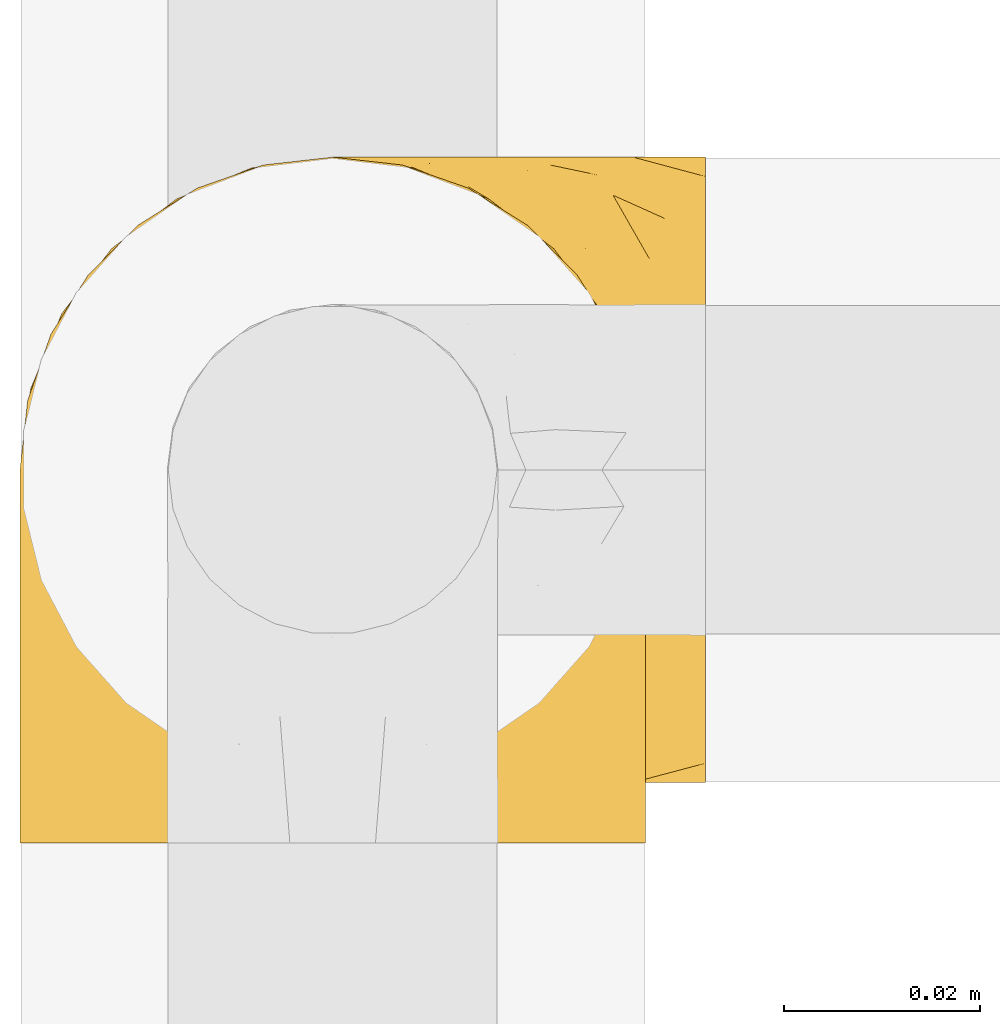
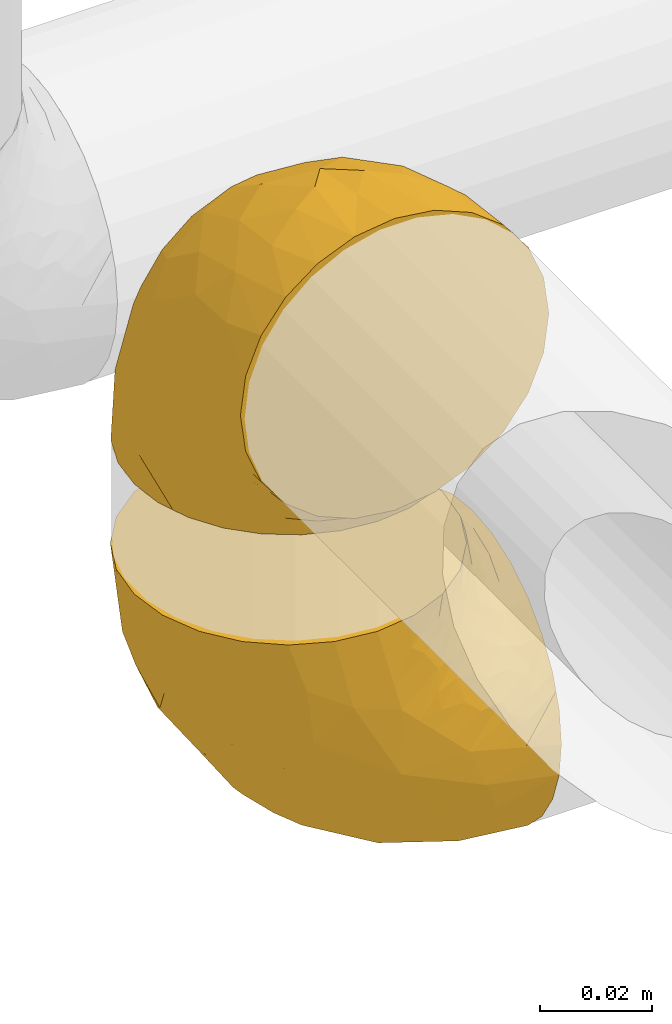
# One storey, part 10 of 39: 2 coverings.
"""IFC2X3 building model written with IfcOpenShell, lengths in millimetres."""

from ifc_helpers import new_model, entity, si_unit, converted_unit, derived_unit, direction, frame, origin, place, context, subcontext, project, spatial, faceted_brep, element, save


model = new_model("IFC2X3")

# Units and contexts
model_context = context("Model", 3, precision=0.01, world=origin(), true_north=direction((6.12303176911189e-17, 1.0)))
body_context = subcontext(model_context, "Body", "Model", "MODEL_VIEW")
ifc_project = project(units=[si_unit("LENGTHUNIT", "METRE", prefix="MILLI"), si_unit("AREAUNIT", "SQUARE_METRE"), si_unit("VOLUMEUNIT", "CUBIC_METRE"), converted_unit("PLANEANGLEUNIT", "DEGREE", entity("IfcRatioMeasure", 0.0174532925199433), si_unit("PLANEANGLEUNIT", "RADIAN"), dimensions=[0, 0, 0, 0, 0, 0, 0]), si_unit("MASSUNIT", "GRAM", prefix="KILO"), derived_unit("MASSDENSITYUNIT", [(si_unit("MASSUNIT", "GRAM", prefix="KILO"), 1), (si_unit("LENGTHUNIT", "METRE"), -3)]), derived_unit("MOMENTOFINERTIAUNIT", [(si_unit("LENGTHUNIT", "METRE"), 4)]), si_unit("TIMEUNIT", "SECOND"), si_unit("FREQUENCYUNIT", "HERTZ"), si_unit("THERMODYNAMICTEMPERATUREUNIT", "DEGREE_CELSIUS"), derived_unit("THERMALTRANSMITTANCEUNIT", [(si_unit("MASSUNIT", "GRAM", prefix="KILO"), 1), (si_unit("THERMODYNAMICTEMPERATUREUNIT", "KELVIN"), -1), (si_unit("TIMEUNIT", "SECOND"), -3)]), derived_unit("VOLUMETRICFLOWRATEUNIT", [(si_unit("LENGTHUNIT", "METRE"), 3), (si_unit("TIMEUNIT", "SECOND"), -1)]), derived_unit("MASSFLOWRATEUNIT", [(si_unit("MASSUNIT", "GRAM", prefix="KILO"), 1), (si_unit("TIMEUNIT", "SECOND"), -1)]), derived_unit("ROTATIONALFREQUENCYUNIT", [(si_unit("TIMEUNIT", "SECOND"), -1)]), si_unit("ELECTRICCURRENTUNIT", "AMPERE"), si_unit("ELECTRICVOLTAGEUNIT", "VOLT"), si_unit("POWERUNIT", "WATT"), si_unit("FORCEUNIT", "NEWTON", prefix="KILO"), si_unit("ILLUMINANCEUNIT", "LUX"), si_unit("LUMINOUSFLUXUNIT", "LUMEN"), si_unit("LUMINOUSINTENSITYUNIT", "CANDELA"), derived_unit("USERDEFINED", [(si_unit("MASSUNIT", "GRAM", prefix="KILO"), -1), (si_unit("LENGTHUNIT", "METRE"), -2), (si_unit("TIMEUNIT", "SECOND"), 3), (si_unit("LUMINOUSFLUXUNIT", "LUMEN"), 1)]), derived_unit("LINEARVELOCITYUNIT", [(si_unit("LENGTHUNIT", "METRE"), 1), (si_unit("TIMEUNIT", "SECOND"), -1)]), si_unit("PRESSUREUNIT", "PASCAL"), derived_unit("USERDEFINED", [(si_unit("LENGTHUNIT", "METRE"), -2), (si_unit("MASSUNIT", "GRAM", prefix="KILO"), 1), (si_unit("TIMEUNIT", "SECOND"), -2)]), derived_unit("LINEARFORCEUNIT", [(si_unit("MASSUNIT", "GRAM", prefix="KILO"), 1), (si_unit("LENGTHUNIT", "METRE"), 1), (si_unit("TIMEUNIT", "SECOND"), -2), (si_unit("LENGTHUNIT", "METRE"), -1)]), derived_unit("PLANARFORCEUNIT", [(si_unit("MASSUNIT", "GRAM", prefix="KILO"), 1), (si_unit("LENGTHUNIT", "METRE"), 1), (si_unit("TIMEUNIT", "SECOND"), -2), (si_unit("LENGTHUNIT", "METRE"), -2)])], contexts=[model_context])

# Site, building, storey
site_placement = place(None, origin())
site = spatial("IfcSite", under=ifc_project, at=site_placement, CompositionType="ELEMENT")
building_placement = place(site_placement, origin())
building = spatial("IfcBuilding", under=site, at=building_placement, CompositionType="ELEMENT")
storey_placement = place(building_placement, frame((0.0, 0.0, 24000.0)))
storey = spatial("IfcBuildingStorey", under=building, at=storey_placement, Name="07", CompositionType="ELEMENT", Elevation=24000.0)

# Coverings
covering_1_placement = place(storey_placement, frame((26666.66, 8211.58, 3260.4)))
element("IfcCovering", 1, at=covering_1_placement, inside=storey, Name=":ADSK_", ObjectType=":ADSK_", PredefinedType="INSULATION", context=body_context, shape_type="Brep", body=[
    faceted_brep([(26.36, 70.65, 1.6), (33.45, 71.45, 1.6), (40.54, 70.65, 1.6), (47.27, 68.29, 1.6), (53.31, 64.49, 1.6), (58.35, 59.45, 1.6), (62.14, 53.41, 1.6), (64.5, 46.68, 1.6), (65.3, 39.6, 1.6), (64.86, 35.69, 1.6), (64.5, 32.5, 1.6), (63.32, 29.14, 1.6), (62.14, 25.77, 1.6), (58.34, 19.73, 1.6), (53.3, 14.69, 1.6), (47.26, 10.9, 1.6), (40.53, 8.54, 1.6), (33.45, 7.75, 1.6), (26.35, 8.54, 1.6), (19.62, 10.9, 1.6), (13.58, 14.7, 1.6), (8.54, 19.74, 1.6), (4.75, 25.78, 1.6), (3.57, 29.15, 1.6), (2.39, 32.51, 1.6), (2.03, 35.69, 1.6), (1.81, 37.64, 1.6), (1.6, 39.6, 1.6), (2.39, 46.69, 1.6), (4.75, 53.42, 1.6), (8.55, 59.46, 1.6), (13.59, 64.5, 1.6), (19.63, 68.29, 1.6), (61.03, 1.6, 23.67), (62.62, 1.6, 27.51), (64.21, 1.6, 31.35), (64.78, 1.6, 35.67), (65.04, 1.6, 37.63), (65.3, 1.6, 39.6), (64.21, 1.6, 47.84), (61.03, 1.6, 55.52), (55.97, 1.6, 62.12), (49.37, 1.6, 67.18), (41.69, 1.6, 70.36), (33.45, 1.6, 71.45), (25.2, 1.6, 70.36), (17.52, 1.6, 67.18), (10.92, 1.6, 62.12), (5.86, 1.6, 55.52), (2.68, 1.6, 47.84), (1.6, 1.6, 39.6), (2.11, 1.6, 35.67), (2.68, 1.6, 31.35), (4.27, 1.6, 27.51), (5.86, 1.6, 23.67), (8.39, 1.6, 20.37), (10.92, 1.6, 17.07), (17.52, 1.6, 12.01), (25.2, 1.6, 8.83), (33.45, 1.6, 7.75), (41.69, 1.6, 8.83), (49.37, 1.6, 12.01), (55.97, 1.6, 17.07), (58.5, 1.6, 20.37), (2.87, 35.56, 33.94), (1.6, 34.5, 20.6), (1.6, 31.03, 24.07), (1.6, 27.55, 27.55), (1.6, 24.07, 31.03), (1.6, 20.6, 34.5), (33.45, 14.96, 68.79), (10.76, 32.2, 53.62), (5.89, 25.13, 50.17), (9.64, 17.37, 58.62), (22.45, 17.86, 67.51), (16.56, 27.91, 61.03), (15.17, 13.85, 64.5), (12.49, 61.37, 17.98), (25.02, 34.87, 61.71), (18.64, 44.22, 52.25), (2.29, 43.56, 16.72), (6.11, 40.93, 39.09), (5.18, 48.36, 25.86), (2.43, 17.22, 44.07), (11.11, 44.67, 44.36), (26.19, 63.86, 31.35), (24.02, 68.09, 17.72), (19.02, 61.87, 29.45), (4.77, 12.15, 52.37), (1.6, 17.69, 35.28), (1.6, 14.79, 36.06), (1.6, 11.89, 36.84), (1.6, 8.99, 37.61), (1.6, 7.14, 38.11), (1.6, 5.29, 38.61), (7.57, 56.77, 14.07), (17.54, 66.08, 13.65), (33.45, 68.79, 14.96), (4.36, 51.2, 13.32), (1.6, 39.1, 3.44), (1.6, 38.61, 5.29), (1.6, 37.61, 8.99), (1.6, 36.84, 11.89), (1.6, 36.06, 14.79), (1.6, 35.28, 17.69), (9.86, 54.2, 29.19), (14.05, 58.65, 28.91), (28.37, 21.36, 68.17), (33.45, 66.13, 28.33), (25.8, 46.99, 53.45), (33.45, 39.66, 58.56), (33.45, 50.99, 50.99), (22.54, 55.34, 43.14), (15.6, 53.83, 39.23), (33.45, 28.33, 66.13), (28.45, 55.34, 45.6), (33.45, 58.56, 39.66), (9.47, 6.06, 18.04), (5.83, 8.03, 22.76), (5.65, 11.06, 21.95), (2.31, 8.19, 32.18), (2.89, 10.89, 29.08), (2.68, 24.37, 20.77), (22.04, 9.23, 4.75), (5.47, 22.33, 11.03), (5.05, 24.59, 6.78), (7.86, 20.19, 5.68), (25.25, 5.45, 7.71), (28.09, 7.56, 4.42), (33.45, 5.94, 5.94), (12.77, 6.36, 14.52), (2.62, 29.84, 11.63), (3.56, 28.12, 6.6), (11.92, 14.94, 7.33), (11.98, 11.12, 12.48), (17.45, 9.87, 7.99), (17.1, 6.36, 11.14), (7.66, 16.34, 14.07), (4.47, 22.18, 15.37), (7.62, 18.62, 10.81), (2.29, 32.34, 7.89), (3.16, 15.29, 26.18), (16.64, 11.7, 5.8), (12.23, 13.14, 9.94), (4.54, 15.04, 22.23), (7.84, 10.61, 18.39), (2.55, 27.21, 17.71), (7.37, 14.05, 16.87), (3.18, 27.14, 13.24), (4.97, 5.74, 24.95), (2.38, 19.92, 26.59), (1.99, 23.61, 26.16), (3.56, 19.14, 22.11), (4.66, 20.12, 17.43), (44.85, 9.23, 4.75), (50.24, 11.69, 5.8), (49.43, 9.87, 7.99), (59.23, 16.33, 14.07), (54.76, 13.17, 10.06), (59.54, 18.65, 11.54), (41.64, 5.45, 7.71), (64.6, 32.33, 7.89), (65.3, 37.61, 8.99), (65.3, 36.84, 11.89), (65.3, 36.06, 14.79), (38.79, 7.56, 4.42), (62.38, 14.85, 22.42), (64.44, 17.26, 27.95), (61.27, 10.58, 22.22), (65.3, 3.44, 39.1), (65.3, 11.89, 36.84), (65.3, 8.99, 37.61), (65.3, 5.29, 38.61), (59.93, 5.65, 21.49), (62.73, 6.88, 26.52), (60.51, 14.93, 18.09), (59.05, 10.6, 18.39), (56.02, 11.09, 13.88), (49.79, 6.36, 11.14), (64.58, 8.19, 32.18), (65.3, 20.6, 34.5), (65.3, 24.07, 31.03), (64.27, 29.86, 11.65), (59.01, 20.16, 5.67), (61.84, 24.58, 6.81), (65.3, 38.61, 5.29), (65.3, 38.11, 7.14), (54.97, 14.93, 7.34), (65.3, 14.79, 36.06), (64.66, 12.32, 31.38), (63.94, 23.91, 19.83), (65.3, 27.55, 27.55), (63.6, 19.33, 22.94), (63.33, 28.11, 6.6), (57.32, 6.0, 17.93), (54.15, 6.44, 14.52), (64.5, 28.13, 17.45), (61.42, 22.32, 11.03), (65.3, 35.28, 17.69), (65.3, 34.5, 20.6), (63.43, 26.65, 12.33), (64.69, 15.34, 30.27), (65.3, 17.69, 35.28), (62.87, 10.31, 25.9), (65.3, 31.03, 24.07), (57.25, 17.37, 58.62), (62.54, 51.19, 13.32), (64.6, 43.56, 16.72), (64.46, 17.22, 44.07), (41.87, 34.87, 61.71), (44.44, 17.86, 67.51), (50.33, 27.92, 61.03), (61.0, 25.12, 50.18), (64.03, 35.57, 33.92), (60.79, 40.93, 39.08), (56.13, 32.19, 53.62), (38.52, 21.36, 68.17), (62.12, 12.15, 52.37), (51.72, 13.85, 64.5), (61.71, 48.35, 25.86), (59.33, 56.76, 14.07), (57.04, 54.19, 29.18), (47.88, 61.86, 29.46), (42.88, 68.09, 17.73), (40.71, 63.85, 31.37), (54.41, 61.36, 17.99), (41.09, 47.0, 53.45), (51.29, 53.81, 39.25), (52.85, 58.64, 28.92), (49.36, 66.07, 13.65), (48.25, 44.24, 52.23), (44.35, 55.34, 43.13), (55.79, 44.67, 44.36), (38.44, 55.34, 45.6)], [[[0, 1, 2, 3, 4, 5, 6, 7, 8, 9, 10, 11, 12, 13, 14, 15, 16, 17, 18, 19, 20, 21, 22, 23, 24, 25, 26, 27, 28, 29, 30, 31, 32]], [[33, 34, 35, 36, 37, 38, 39, 40, 41, 42, 43, 44, 45, 46, 47, 48, 49, 50, 51, 52, 53, 54, 55, 56, 57, 58, 59, 60, 61, 62, 63]], [[64, 65, 66, 67, 68, 69]], [[45, 44, 70]], [[71, 72, 73]], [[74, 75, 76]], [[77, 31, 30]], [[75, 78, 79]], [[27, 80, 28]], [[74, 46, 45]], [[64, 81, 82]], [[46, 76, 47]], [[83, 50, 49]], [[48, 47, 73]], [[71, 79, 84]], [[85, 86, 87]], [[49, 48, 88]], [[83, 69, 89, 90, 91, 92, 93, 94, 50]], [[95, 77, 30]], [[75, 74, 78]], [[87, 86, 96]], [[96, 86, 32]], [[96, 32, 31]], [[0, 86, 97]], [[83, 64, 69]], [[98, 80, 82]], [[73, 72, 88]], [[64, 80, 65]], [[1, 0, 97]], [[80, 27, 99, 100, 101, 102, 103, 104, 65]], [[77, 105, 106]], [[64, 82, 80]], [[70, 107, 45]], [[77, 95, 105]], [[82, 95, 98]], [[95, 30, 29]], [[74, 107, 78]], [[86, 0, 32]], [[72, 71, 81]], [[85, 108, 86]], [[76, 73, 47]], [[71, 84, 81]], [[109, 110, 111]], [[87, 112, 85]], [[79, 109, 112]], [[79, 112, 113]], [[88, 83, 49]], [[64, 83, 72]], [[31, 77, 96]], [[87, 96, 77]], [[98, 95, 29]], [[105, 95, 82]], [[81, 105, 82]], [[105, 84, 113]], [[29, 28, 98]], [[114, 107, 70]], [[80, 98, 28]], [[73, 75, 71]], [[79, 71, 75]], [[74, 76, 46]], [[73, 76, 75]], [[78, 107, 114]], [[45, 107, 74]], [[87, 113, 112]], [[115, 85, 112]], [[109, 79, 78]], [[113, 87, 106]], [[116, 115, 111]], [[116, 108, 85]], [[79, 113, 84]], [[109, 78, 110]], [[115, 109, 111]], [[85, 115, 116]], [[109, 115, 112]], [[72, 81, 64]], [[105, 81, 84]], [[73, 88, 48]], [[83, 88, 72]], [[86, 108, 97]], [[78, 114, 110]], [[113, 106, 105]], [[87, 77, 106]], [[117, 118, 119]], [[52, 120, 54, 53]], [[91, 120, 52]], [[91, 90, 120]], [[90, 121, 120]], [[122, 67, 66]], [[18, 123, 19]], [[124, 125, 126]], [[127, 59, 58]], [[128, 129, 127]], [[130, 57, 117]], [[131, 132, 125]], [[19, 133, 20]], [[128, 18, 17]], [[134, 135, 136]], [[137, 138, 139]], [[131, 103, 140]], [[22, 140, 23]], [[131, 65, 104, 103]], [[99, 27, 26, 25, 24, 101, 100]], [[141, 118, 121]], [[19, 123, 142]], [[52, 51, 50, 94, 93, 92, 91]], [[129, 128, 17]], [[117, 56, 118]], [[135, 134, 143]], [[139, 126, 133]], [[119, 144, 145]], [[127, 135, 123]], [[136, 58, 57]], [[101, 24, 23]], [[124, 138, 146]], [[140, 101, 23]], [[145, 147, 134]], [[140, 132, 131]], [[140, 103, 102, 101]], [[140, 22, 132]], [[146, 148, 124]], [[121, 69, 141]], [[55, 149, 118]], [[150, 151, 152]], [[147, 137, 134]], [[144, 150, 152]], [[152, 151, 122]], [[138, 122, 146]], [[59, 127, 129]], [[123, 18, 128]], [[58, 136, 127]], [[135, 127, 136]], [[121, 90, 89, 69]], [[120, 121, 149]], [[122, 66, 146]], [[153, 122, 138]], [[141, 69, 68]], [[127, 123, 128]], [[123, 135, 142]], [[143, 142, 135]], [[19, 142, 133]], [[66, 65, 146]], [[148, 65, 131]], [[22, 21, 132]], [[125, 132, 21]], [[126, 125, 21]], [[148, 125, 124]], [[21, 20, 126]], [[133, 126, 20]], [[139, 138, 124]], [[153, 138, 137]], [[126, 139, 124]], [[139, 133, 143]], [[147, 153, 137]], [[152, 122, 153]], [[134, 136, 130]], [[137, 139, 143]], [[144, 147, 145]], [[153, 147, 152]], [[65, 148, 146]], [[125, 148, 131]], [[141, 144, 119]], [[55, 54, 149]], [[137, 143, 134]], [[142, 143, 133]], [[130, 117, 145]], [[57, 56, 117]], [[134, 130, 145]], [[57, 130, 136]], [[150, 144, 141]], [[147, 144, 152]], [[141, 68, 150]], [[151, 68, 67]], [[117, 119, 145]], [[141, 119, 118]], [[68, 151, 150]], [[122, 151, 67]], [[118, 56, 55]], [[120, 149, 54]], [[118, 149, 121]], [[154, 155, 156]], [[157, 158, 159]], [[129, 160, 59]], [[161, 162, 163, 164]], [[165, 160, 129]], [[166, 167, 168]], [[169, 38, 37, 36, 35, 170, 171, 172]], [[63, 173, 174]], [[175, 176, 177]], [[60, 178, 61]], [[179, 35, 34, 33]], [[160, 60, 59]], [[180, 167, 181]], [[129, 17, 165]], [[182, 161, 164]], [[183, 13, 184]], [[9, 8, 185, 186, 162, 10]], [[187, 155, 15]], [[188, 179, 189]], [[187, 15, 14]], [[190, 191, 192]], [[182, 193, 161]], [[194, 176, 168]], [[176, 195, 177]], [[196, 190, 197]], [[11, 10, 162]], [[11, 161, 12]], [[187, 14, 183]], [[12, 161, 193]], [[156, 158, 177]], [[165, 17, 16]], [[194, 195, 176]], [[187, 159, 158]], [[179, 174, 189]], [[182, 164, 198, 199]], [[200, 199, 196]], [[193, 184, 13]], [[194, 168, 173]], [[201, 202, 189]], [[16, 154, 165]], [[160, 156, 178]], [[160, 165, 154]], [[178, 60, 160]], [[170, 35, 179]], [[188, 170, 179]], [[189, 174, 203]], [[174, 179, 33]], [[201, 189, 203]], [[181, 192, 191]], [[167, 180, 201]], [[192, 175, 190]], [[159, 190, 157]], [[15, 154, 16]], [[204, 196, 199]], [[204, 191, 190]], [[160, 154, 156]], [[15, 155, 154]], [[158, 155, 187]], [[203, 173, 168]], [[192, 181, 167]], [[190, 196, 204]], [[200, 196, 197]], [[184, 193, 182]], [[13, 12, 193]], [[200, 184, 182]], [[184, 200, 183]], [[187, 183, 197]], [[14, 13, 183]], [[162, 161, 11]], [[63, 62, 173]], [[174, 33, 63]], [[173, 62, 194]], [[174, 173, 203]], [[62, 61, 194]], [[195, 61, 178]], [[61, 195, 194]], [[177, 195, 178]], [[156, 177, 178]], [[175, 192, 166]], [[166, 168, 176]], [[167, 203, 168]], [[175, 166, 176]], [[167, 166, 192]], [[177, 157, 175]], [[190, 175, 157]], [[187, 197, 159]], [[190, 159, 197]], [[177, 158, 157]], [[155, 158, 156]], [[167, 201, 203]], [[200, 197, 183]], [[202, 201, 180]], [[202, 188, 189]], [[199, 200, 182]], [[41, 40, 205]], [[206, 207, 7]], [[208, 38, 169, 172, 171, 170, 188, 202, 180]], [[209, 210, 211]], [[212, 213, 214]], [[212, 215, 205]], [[43, 210, 216]], [[217, 40, 39]], [[216, 114, 70]], [[208, 213, 212]], [[205, 40, 217]], [[218, 42, 41]], [[216, 209, 114]], [[42, 218, 210]], [[214, 213, 219]], [[219, 220, 221]], [[199, 207, 213]], [[213, 207, 219]], [[8, 7, 207]], [[222, 223, 224]], [[4, 225, 5]], [[2, 97, 223]], [[110, 226, 111]], [[225, 220, 5]], [[227, 221, 228]], [[223, 229, 3]], [[2, 223, 3]], [[230, 231, 226]], [[224, 223, 108]], [[42, 210, 43]], [[230, 209, 211]], [[222, 225, 229]], [[38, 208, 39]], [[3, 229, 4]], [[213, 180, 181, 191, 204, 199]], [[220, 206, 6]], [[5, 220, 6]], [[207, 199, 198, 164, 163, 162, 186, 185, 8]], [[212, 214, 215]], [[218, 205, 211]], [[211, 215, 230]], [[226, 110, 209]], [[222, 231, 227]], [[222, 224, 231]], [[213, 208, 180]], [[217, 208, 212]], [[222, 229, 223]], [[225, 4, 229]], [[221, 220, 225]], [[206, 220, 219]], [[228, 221, 225]], [[214, 221, 232]], [[207, 206, 219]], [[44, 43, 70]], [[7, 6, 206]], [[230, 215, 232]], [[211, 205, 215]], [[205, 218, 41]], [[210, 218, 211]], [[43, 216, 70]], [[209, 216, 210]], [[233, 116, 111]], [[230, 232, 227]], [[224, 116, 233]], [[230, 226, 209]], [[224, 108, 116]], [[230, 227, 231]], [[221, 227, 232]], [[233, 226, 231]], [[225, 222, 228]], [[226, 233, 111]], [[224, 233, 231]], [[221, 214, 219]], [[214, 232, 215]], [[208, 217, 39]], [[205, 217, 212]], [[97, 2, 1]], [[97, 108, 223]], [[110, 114, 209]], [[227, 228, 222]]]),
])
covering_2_placement = place(storey_placement, frame((26666.66, 8217.73, 3166.55)))
element("IfcCovering", 2, at=covering_2_placement, inside=storey, Name=":ADSK_", ObjectType=":ADSK_", PredefinedType="INSULATION", context=body_context, shape_type="Brep", body=[
    faceted_brep([(71.45, 26.36, 2.39), (71.45, 33.45, 1.6), (71.45, 40.54, 2.39), (71.45, 47.27, 4.75), (71.45, 53.31, 8.55), (71.45, 58.35, 13.59), (71.45, 62.14, 19.63), (71.45, 64.5, 26.36), (71.45, 65.3, 33.45), (71.45, 64.86, 37.35), (71.45, 64.5, 40.54), (71.45, 63.32, 43.9), (71.45, 62.14, 47.27), (71.45, 58.34, 53.31), (71.45, 53.3, 58.35), (71.45, 47.26, 62.14), (71.45, 40.53, 64.5), (71.45, 33.45, 65.3), (71.45, 26.35, 64.5), (71.45, 19.62, 62.14), (71.45, 13.58, 58.34), (71.45, 8.54, 53.3), (71.45, 4.75, 47.26), (71.45, 3.57, 43.89), (71.45, 2.39, 40.53), (71.45, 2.03, 37.35), (71.45, 1.81, 35.4), (71.45, 1.6, 33.45), (71.45, 2.39, 26.35), (71.45, 4.75, 19.62), (71.45, 8.55, 13.58), (71.45, 13.59, 8.54), (71.45, 19.63, 4.75), (49.37, 61.03, 71.45), (45.53, 62.62, 71.45), (41.69, 64.21, 71.45), (37.37, 64.78, 71.45), (35.41, 65.04, 71.45), (33.45, 65.3, 71.45), (25.2, 64.21, 71.45), (17.52, 61.03, 71.45), (10.92, 55.97, 71.45), (5.86, 49.37, 71.45), (2.68, 41.69, 71.45), (1.6, 33.45, 71.45), (2.68, 25.2, 71.45), (5.86, 17.52, 71.45), (10.92, 10.92, 71.45), (17.52, 5.86, 71.45), (25.2, 2.68, 71.45), (33.45, 1.6, 71.45), (37.37, 2.11, 71.45), (41.69, 2.68, 71.45), (45.53, 4.27, 71.45), (49.37, 5.86, 71.45), (52.67, 8.39, 71.45), (55.97, 10.92, 71.45), (61.03, 17.52, 71.45), (64.21, 25.2, 71.45), (65.3, 33.45, 71.45), (64.21, 41.69, 71.45), (61.03, 49.37, 71.45), (55.97, 55.97, 71.45), (52.67, 58.5, 71.45), (39.1, 2.87, 37.48), (52.45, 1.6, 38.54), (48.97, 1.6, 42.01), (45.49, 1.6, 45.49), (42.01, 1.6, 48.97), (38.54, 1.6, 52.45), (4.25, 33.45, 58.08), (19.42, 10.76, 40.84), (22.87, 5.89, 47.91), (14.43, 9.64, 55.67), (5.53, 22.45, 55.18), (12.01, 16.56, 45.13), (8.54, 15.17, 59.19), (55.06, 12.49, 11.67), (11.33, 25.02, 38.17), (20.79, 18.64, 28.82), (56.32, 2.29, 29.48), (33.95, 6.11, 32.11), (47.18, 5.18, 24.68), (28.97, 2.43, 55.82), (28.68, 11.11, 28.37), (41.69, 26.19, 9.18), (55.32, 24.02, 4.95), (43.59, 19.02, 11.17), (20.67, 4.77, 60.89), (37.76, 1.6, 55.35), (36.98, 1.6, 58.25), (36.2, 1.6, 61.15), (35.43, 1.6, 64.05), (34.93, 1.6, 65.9), (34.44, 1.6, 67.75), (58.97, 7.57, 16.27), (59.39, 17.54, 6.97), (58.08, 33.45, 4.25), (59.72, 4.36, 21.84), (69.6, 1.6, 33.94), (67.75, 1.6, 34.44), (64.05, 1.6, 35.43), (61.15, 1.6, 36.2), (58.25, 1.6, 36.98), (55.35, 1.6, 37.76), (43.85, 9.86, 18.84), (44.13, 14.05, 14.39), (4.87, 28.37, 51.68), (44.71, 33.45, 6.91), (19.59, 25.8, 26.05), (14.48, 33.45, 33.38), (22.05, 33.45, 22.05), (29.9, 22.54, 17.7), (33.81, 15.6, 19.21), (6.91, 33.45, 44.71), (27.44, 28.45, 17.7), (33.38, 33.45, 14.48), (55.01, 9.47, 66.98), (50.28, 5.83, 65.01), (51.09, 5.65, 61.98), (40.86, 2.31, 64.85), (43.96, 2.89, 62.15), (52.27, 2.68, 48.67), (68.29, 22.04, 63.81), (62.01, 5.47, 50.71), (66.26, 5.05, 48.45), (67.36, 7.86, 52.85), (65.34, 25.25, 67.6), (68.62, 28.09, 65.48), (67.1, 33.45, 67.1), (58.52, 12.77, 66.68), (61.41, 2.62, 43.2), (66.44, 3.56, 44.92), (65.71, 11.92, 58.1), (60.56, 11.98, 61.92), (65.05, 17.45, 63.17), (61.9, 17.1, 66.68), (58.97, 7.66, 56.7), (57.67, 4.47, 50.86), (62.23, 7.62, 54.42), (65.15, 2.29, 40.7), (46.86, 3.16, 57.76), (67.24, 16.64, 61.34), (63.1, 12.23, 59.9), (50.81, 4.54, 58.0), (54.65, 7.84, 62.43), (55.33, 2.55, 45.83), (56.17, 7.37, 58.99), (59.8, 3.18, 45.9), (48.09, 4.97, 67.3), (46.45, 2.38, 53.12), (46.88, 1.99, 49.43), (50.93, 3.56, 53.9), (55.61, 4.66, 52.92), (68.29, 44.85, 63.81), (67.24, 50.24, 61.35), (65.05, 49.43, 63.17), (58.97, 59.23, 56.72), (62.98, 54.76, 59.87), (61.5, 59.54, 54.39), (65.34, 41.64, 67.59), (65.15, 64.6, 40.71), (64.05, 65.3, 35.43), (61.15, 65.3, 36.2), (58.25, 65.3, 36.98), (68.62, 38.79, 65.48), (50.62, 62.38, 58.19), (45.09, 64.44, 55.78), (50.82, 61.27, 62.46), (33.94, 65.3, 69.6), (36.2, 65.3, 61.15), (35.43, 65.3, 64.05), (34.44, 65.3, 67.75), (51.55, 59.93, 67.39), (46.52, 62.73, 66.16), (54.95, 60.51, 58.11), (54.65, 59.05, 62.44), (59.16, 56.02, 61.95), (61.9, 49.79, 66.68), (40.86, 64.58, 64.85), (38.54, 65.3, 52.45), (42.01, 65.3, 48.97), (61.39, 64.27, 43.18), (67.37, 59.01, 52.88), (66.23, 61.84, 48.46), (67.75, 65.3, 34.44), (65.9, 65.3, 34.93), (65.7, 54.97, 58.11), (36.98, 65.3, 58.25), (41.66, 64.66, 60.72), (53.21, 63.94, 49.13), (45.49, 65.3, 45.49), (50.1, 63.6, 53.71), (66.44, 63.33, 44.93), (55.11, 57.32, 67.04), (58.52, 54.15, 66.6), (55.59, 64.5, 44.91), (62.01, 61.42, 50.72), (55.35, 65.3, 37.76), (52.45, 65.3, 38.54), (60.71, 63.43, 46.39), (47.15, 62.87, 62.73), (42.77, 64.69, 57.7), (37.76, 65.3, 55.35), (48.97, 65.3, 42.01), (14.42, 57.25, 55.67), (59.72, 62.54, 21.85), (56.32, 64.6, 29.49), (28.97, 64.46, 55.82), (11.33, 41.87, 38.17), (5.53, 44.44, 55.18), (12.01, 50.33, 45.12), (22.86, 61.0, 47.92), (39.12, 64.03, 37.47), (33.96, 60.79, 32.11), (19.42, 56.13, 40.85), (4.87, 38.52, 51.68), (20.67, 62.12, 60.89), (8.55, 51.72, 59.19), (47.18, 61.71, 24.69), (58.97, 59.33, 16.28), (43.86, 57.04, 18.85), (43.58, 47.88, 11.19), (55.32, 42.88, 4.95), (41.67, 40.71, 9.19), (55.05, 54.41, 11.68), (19.59, 41.09, 26.05), (33.79, 51.29, 19.23), (44.12, 52.85, 14.4), (59.39, 49.36, 6.97), (20.81, 48.25, 28.8), (29.91, 44.35, 17.7), (28.68, 55.79, 28.37), (27.45, 38.44, 17.7)], [[[0, 1, 2, 3, 4, 5, 6, 7, 8, 9, 10, 11, 12, 13, 14, 15, 16, 17, 18, 19, 20, 21, 22, 23, 24, 25, 26, 27, 28, 29, 30, 31, 32]], [[33, 34, 35, 36, 37, 38, 39, 40, 41, 42, 43, 44, 45, 46, 47, 48, 49, 50, 51, 52, 53, 54, 55, 56, 57, 58, 59, 60, 61, 62, 63]], [[64, 65, 66, 67, 68, 69]], [[45, 44, 70]], [[71, 72, 73]], [[74, 75, 76]], [[77, 31, 30]], [[75, 78, 79]], [[27, 80, 28]], [[74, 46, 45]], [[64, 81, 82]], [[46, 76, 47]], [[83, 50, 49]], [[48, 47, 73]], [[71, 79, 84]], [[85, 86, 87]], [[49, 48, 88]], [[83, 69, 89, 90, 91, 92, 93, 94, 50]], [[95, 77, 30]], [[75, 74, 78]], [[87, 86, 96]], [[96, 86, 32]], [[96, 32, 31]], [[0, 86, 97]], [[83, 64, 69]], [[98, 80, 82]], [[73, 72, 88]], [[64, 80, 65]], [[1, 0, 97]], [[80, 27, 99, 100, 101, 102, 103, 104, 65]], [[77, 105, 106]], [[64, 82, 80]], [[70, 107, 45]], [[77, 95, 105]], [[82, 95, 98]], [[95, 30, 29]], [[74, 107, 78]], [[86, 0, 32]], [[72, 71, 81]], [[85, 108, 86]], [[76, 73, 47]], [[71, 84, 81]], [[109, 110, 111]], [[87, 112, 85]], [[79, 109, 112]], [[79, 112, 113]], [[88, 83, 49]], [[64, 83, 72]], [[31, 77, 96]], [[87, 96, 77]], [[98, 95, 29]], [[105, 95, 82]], [[81, 105, 82]], [[105, 84, 113]], [[29, 28, 98]], [[114, 107, 70]], [[80, 98, 28]], [[73, 75, 71]], [[79, 71, 75]], [[74, 76, 46]], [[73, 76, 75]], [[78, 107, 114]], [[45, 107, 74]], [[87, 113, 112]], [[115, 85, 112]], [[109, 79, 78]], [[113, 87, 106]], [[116, 115, 111]], [[116, 108, 85]], [[79, 113, 84]], [[109, 78, 110]], [[115, 109, 111]], [[85, 115, 116]], [[109, 115, 112]], [[72, 81, 64]], [[105, 81, 84]], [[73, 88, 48]], [[83, 88, 72]], [[86, 108, 97]], [[78, 114, 110]], [[113, 106, 105]], [[87, 77, 106]], [[117, 118, 119]], [[52, 120, 54, 53]], [[91, 120, 52]], [[91, 90, 120]], [[90, 121, 120]], [[122, 67, 66]], [[18, 123, 19]], [[124, 125, 126]], [[127, 59, 58]], [[128, 129, 127]], [[130, 57, 117]], [[131, 132, 125]], [[19, 133, 20]], [[128, 18, 17]], [[134, 135, 136]], [[137, 138, 139]], [[131, 103, 140]], [[22, 140, 23]], [[131, 65, 104, 103]], [[99, 27, 26, 25, 24, 101, 100]], [[141, 118, 121]], [[19, 123, 142]], [[52, 51, 50, 94, 93, 92, 91]], [[129, 128, 17]], [[117, 56, 118]], [[135, 134, 143]], [[139, 126, 133]], [[119, 144, 145]], [[127, 135, 123]], [[136, 58, 57]], [[101, 24, 23]], [[124, 138, 146]], [[140, 101, 23]], [[145, 147, 134]], [[140, 132, 131]], [[140, 103, 102, 101]], [[140, 22, 132]], [[146, 148, 124]], [[121, 69, 141]], [[55, 149, 118]], [[150, 151, 152]], [[147, 137, 134]], [[144, 150, 152]], [[152, 151, 122]], [[138, 122, 146]], [[59, 127, 129]], [[123, 18, 128]], [[58, 136, 127]], [[135, 127, 136]], [[121, 90, 89, 69]], [[120, 121, 149]], [[122, 66, 146]], [[153, 122, 138]], [[141, 69, 68]], [[127, 123, 128]], [[123, 135, 142]], [[143, 142, 135]], [[19, 142, 133]], [[66, 65, 146]], [[148, 65, 131]], [[22, 21, 132]], [[125, 132, 21]], [[126, 125, 21]], [[148, 125, 124]], [[21, 20, 126]], [[133, 126, 20]], [[139, 138, 124]], [[153, 138, 137]], [[126, 139, 124]], [[139, 133, 143]], [[147, 153, 137]], [[152, 122, 153]], [[134, 136, 130]], [[137, 139, 143]], [[144, 147, 145]], [[153, 147, 152]], [[65, 148, 146]], [[125, 148, 131]], [[141, 144, 119]], [[55, 54, 149]], [[137, 143, 134]], [[142, 143, 133]], [[130, 117, 145]], [[57, 56, 117]], [[134, 130, 145]], [[57, 130, 136]], [[150, 144, 141]], [[147, 144, 152]], [[141, 68, 150]], [[151, 68, 67]], [[117, 119, 145]], [[141, 119, 118]], [[68, 151, 150]], [[122, 151, 67]], [[118, 56, 55]], [[120, 149, 54]], [[118, 149, 121]], [[154, 155, 156]], [[157, 158, 159]], [[129, 160, 59]], [[161, 162, 163, 164]], [[165, 160, 129]], [[166, 167, 168]], [[169, 38, 37, 36, 35, 170, 171, 172]], [[63, 173, 174]], [[175, 176, 177]], [[60, 178, 61]], [[179, 35, 34, 33]], [[160, 60, 59]], [[180, 167, 181]], [[129, 17, 165]], [[182, 161, 164]], [[183, 13, 184]], [[9, 8, 185, 186, 162, 10]], [[187, 155, 15]], [[188, 179, 189]], [[187, 15, 14]], [[190, 191, 192]], [[182, 193, 161]], [[194, 176, 168]], [[176, 195, 177]], [[196, 190, 197]], [[11, 10, 162]], [[11, 161, 12]], [[187, 14, 183]], [[12, 161, 193]], [[156, 158, 177]], [[165, 17, 16]], [[194, 195, 176]], [[187, 159, 158]], [[179, 174, 189]], [[182, 164, 198, 199]], [[200, 199, 196]], [[193, 184, 13]], [[174, 173, 201]], [[202, 203, 189]], [[16, 154, 165]], [[160, 156, 178]], [[160, 165, 154]], [[178, 60, 160]], [[170, 35, 179]], [[188, 170, 179]], [[189, 174, 201]], [[174, 179, 33]], [[202, 189, 201]], [[181, 192, 191]], [[167, 180, 202]], [[192, 175, 190]], [[159, 190, 157]], [[15, 154, 16]], [[204, 196, 199]], [[204, 191, 190]], [[160, 154, 156]], [[15, 155, 154]], [[158, 155, 187]], [[201, 173, 168]], [[192, 181, 167]], [[190, 196, 204]], [[200, 196, 197]], [[184, 193, 182]], [[13, 12, 193]], [[200, 184, 182]], [[184, 200, 183]], [[187, 183, 197]], [[14, 13, 183]], [[162, 161, 11]], [[62, 173, 63]], [[174, 33, 63]], [[194, 173, 62]], [[173, 194, 168]], [[62, 61, 194]], [[195, 61, 178]], [[61, 195, 194]], [[177, 195, 178]], [[156, 177, 178]], [[175, 192, 166]], [[166, 168, 176]], [[167, 201, 168]], [[175, 166, 176]], [[167, 166, 192]], [[177, 157, 175]], [[190, 175, 157]], [[187, 197, 159]], [[190, 159, 197]], [[177, 158, 157]], [[155, 158, 156]], [[167, 202, 201]], [[200, 197, 183]], [[203, 202, 180]], [[203, 188, 189]], [[199, 200, 182]], [[41, 40, 205]], [[206, 207, 7]], [[208, 38, 169, 172, 171, 170, 188, 203, 180]], [[209, 210, 211]], [[212, 213, 214]], [[212, 215, 205]], [[43, 210, 216]], [[217, 40, 39]], [[216, 114, 70]], [[208, 213, 212]], [[205, 40, 217]], [[218, 42, 41]], [[216, 209, 114]], [[42, 218, 210]], [[214, 213, 219]], [[219, 220, 221]], [[199, 207, 213]], [[213, 207, 219]], [[8, 7, 207]], [[222, 223, 224]], [[4, 225, 5]], [[2, 97, 223]], [[110, 226, 111]], [[225, 220, 5]], [[227, 221, 228]], [[223, 229, 3]], [[2, 223, 3]], [[230, 231, 226]], [[224, 223, 108]], [[42, 210, 43]], [[230, 209, 211]], [[222, 225, 229]], [[38, 208, 39]], [[3, 229, 4]], [[213, 180, 181, 191, 204, 199]], [[220, 206, 6]], [[5, 220, 6]], [[207, 199, 198, 164, 163, 162, 186, 185, 8]], [[212, 214, 215]], [[218, 205, 211]], [[211, 215, 230]], [[226, 110, 209]], [[222, 231, 227]], [[222, 224, 231]], [[213, 208, 180]], [[217, 208, 212]], [[222, 229, 223]], [[225, 4, 229]], [[221, 220, 225]], [[206, 220, 219]], [[228, 221, 225]], [[214, 221, 232]], [[207, 206, 219]], [[44, 43, 70]], [[7, 6, 206]], [[230, 215, 232]], [[211, 205, 215]], [[205, 218, 41]], [[210, 218, 211]], [[43, 216, 70]], [[209, 216, 210]], [[233, 116, 111]], [[230, 232, 227]], [[224, 116, 233]], [[230, 226, 209]], [[224, 108, 116]], [[230, 227, 231]], [[221, 227, 232]], [[233, 226, 231]], [[225, 222, 228]], [[226, 233, 111]], [[224, 233, 231]], [[221, 214, 219]], [[214, 232, 215]], [[208, 217, 39]], [[205, 217, 212]], [[97, 2, 1]], [[97, 108, 223]], [[110, 114, 209]], [[227, 228, 222]]]),
])

save(model, "model.ifc")
